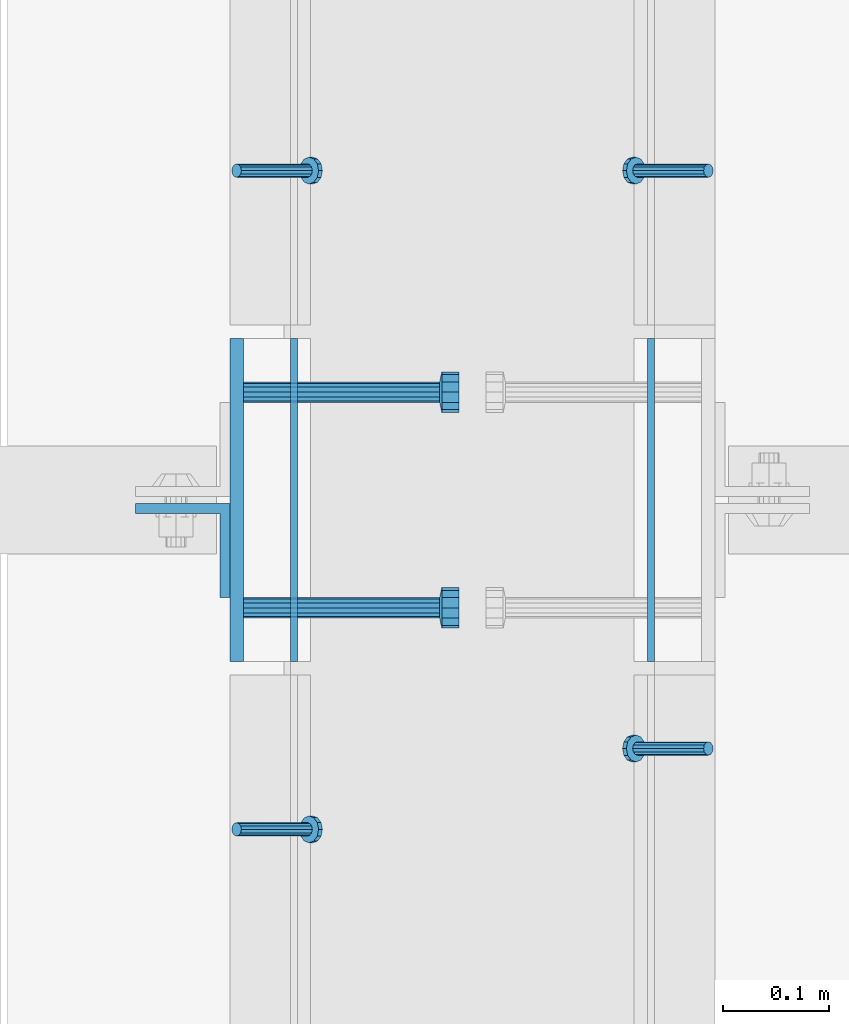
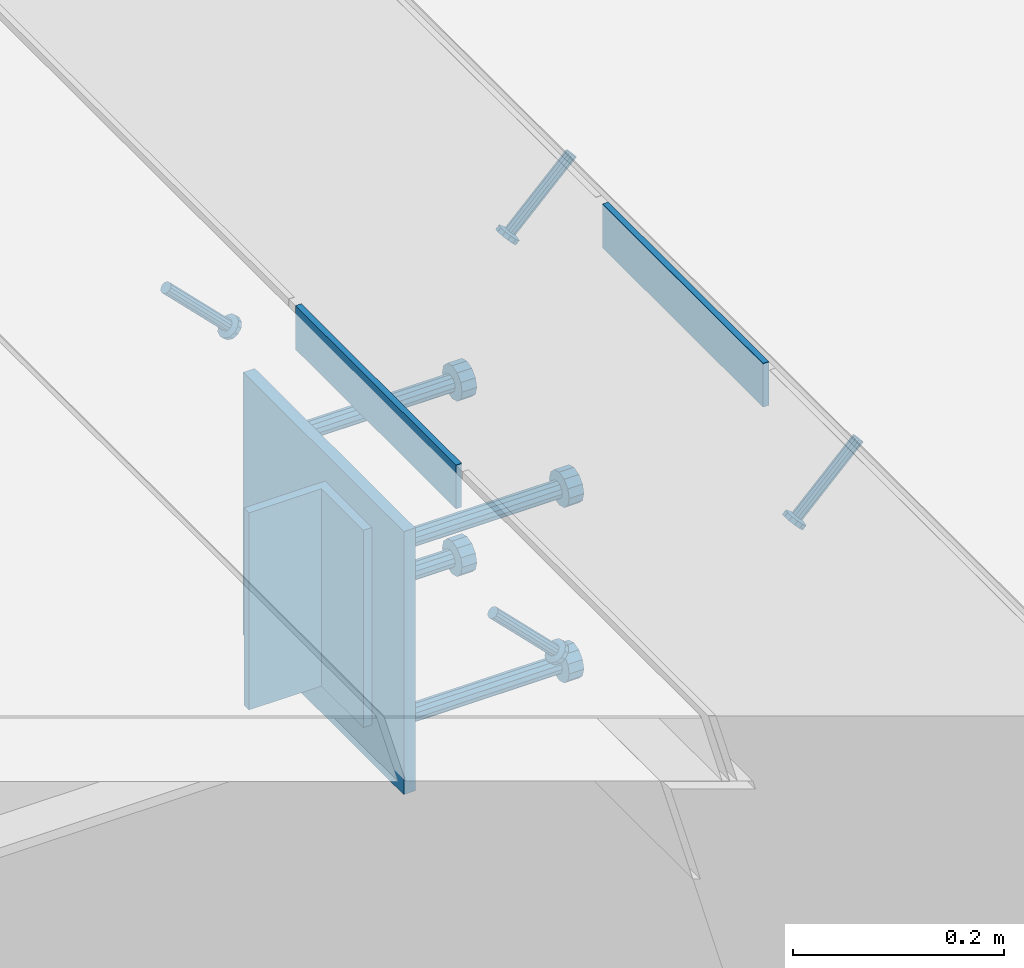
# One storey, part 2146 of 3843: 8 beams, 4 members, 7 elements without a shape of their own.
"""IFC2X3 building model written with IfcOpenShell, lengths in millimetres."""

from ifc_helpers import new_model, si_unit, frame, origin_with_axes, place, context, subcontext, project, spatial, faceted_brep, material, type_object, element, aggregate, save


model = new_model("IFC2X3")

# Units and contexts
model_context = context("Model", 3, precision=1e-05, world=origin_with_axes())
body_context = subcontext(model_context, "Body", "Model", "MODEL_VIEW")
ifc_project = project(units=[si_unit("LENGTHUNIT", "METRE", prefix="MILLI"), si_unit("AREAUNIT", "SQUARE_METRE"), si_unit("VOLUMEUNIT", "CUBIC_METRE"), si_unit("MASSUNIT", "GRAM", prefix="KILO"), si_unit("TIMEUNIT", "SECOND"), si_unit("PLANEANGLEUNIT", "RADIAN"), si_unit("SOLIDANGLEUNIT", "STERADIAN"), si_unit("THERMODYNAMICTEMPERATUREUNIT", "DEGREE_CELSIUS"), si_unit("LUMINOUSINTENSITYUNIT", "LUMEN")], contexts=[model_context])

# Site, building, storey
site_placement = place(None, origin_with_axes())
site = spatial("IfcSite", under=ifc_project, at=site_placement, CompositionType="ELEMENT")
building_placement = place(site_placement, origin_with_axes())
building = spatial("IfcBuilding", under=site, at=building_placement, Name="Undefined", CompositionType="ELEMENT")
storey_placement = place(building_placement, origin_with_axes())
storey = spatial("IfcBuildingStorey", under=building, at=storey_placement, Name="Undefined", CompositionType="ELEMENT", Elevation=0.0)

# Assembly, beam
assembly_1_placement = place(storey_placement, origin_with_axes())
assembly_1 = element("IfcElementAssembly", 1, at=assembly_1_placement, inside=storey, Name="EMBED PLATE", AssemblyPlace="NOTDEFINED", PredefinedType="RIGID_FRAME")
ifc_material_1 = material(Name="STEEL/A36")
beam_type_1 = type_object("IfcBeamType", PredefinedType="NOTDEFINED")
beam_1_placement = place(assembly_1_placement, frame((62391.9249969482, 16381.4125, 30454.6), z_axis=(0.0, 0.0, 1.0), x_axis=(0.0, -1.0, 0.0)))
beam_1 = element("IfcBeam", 2, at=beam_1_placement, type_object=beam_type_1, material=ifc_material_1, Name="PLATE", context=body_context, shape_type="Brep", body=[
    faceted_brep([(0.0, 3.17499999999927, -25.4000000000015), (0.0, 3.17499999999927, 25.4000000000015), (304.800000000003, 3.17500000000291, 25.4000000000015), (304.800000000003, 3.17500000000291, -25.4000000000015), (0.0, -3.17499999999927, 25.4000000000015), (304.800000000003, -3.17500000000291, 25.4000000000015), (0.0, -3.17499999999927, -25.4000000000015), (304.800000000003, -3.17500000000291, -25.4000000000015)], [[[0, 1, 2, 3]], [[1, 4, 5, 2]], [[4, 6, 7, 5]], [[6, 0, 3, 7]], [[5, 7, 3, 2]], [[6, 4, 1, 0]]]),
])

assembly_2_placement = place(storey_placement, origin_with_axes())
assembly_2 = element("IfcElementAssembly", 3, at=assembly_2_placement, inside=storey, Name="EMBED PLATE", AssemblyPlace="NOTDEFINED", PredefinedType="RIGID_FRAME")
beam_2_placement = place(assembly_2_placement, frame((62728.4750030518, 16076.6125, 30454.6), z_axis=(0.0, 0.0, 1.0), x_axis=(0.0, 1.0, 0.0)))
beam_2 = element("IfcBeam", 4, at=beam_2_placement, type_object=beam_type_1, material=ifc_material_1, Name="PLATE", context=body_context, shape_type="Brep", body=[
    faceted_brep([(0.0, 3.17499999999927, -25.4000000000015), (0.0, 3.17499999999927, 25.4000000000015), (304.800000000003, 3.17500000000291, 25.4000000000015), (304.800000000003, 3.17500000000291, -25.4000000000015), (0.0, -3.17499999999927, 25.4000000000015), (304.800000000003, -3.17500000000291, 25.4000000000015), (0.0, -3.17499999999927, -25.4000000000015), (304.800000000003, -3.17500000000291, -25.4000000000015)], [[[0, 1, 2, 3]], [[1, 4, 5, 2]], [[4, 6, 7, 5]], [[6, 0, 3, 7]], [[5, 7, 3, 2]], [[6, 4, 1, 0]]]),
])
aggregate(assembly_2, [beam_2])

# Assembly, member
assembly_3_placement = place(storey_placement, origin_with_axes())
assembly_3 = element("IfcElementAssembly", 5, at=assembly_3_placement, inside=storey, Name="ANGLE", AssemblyPlace="NOTDEFINED", PredefinedType="RIGID_FRAME")
ifc_material_2 = material(Name="STEEL/A108")
member_type = type_object("IfcMemberType", PredefinedType="NOTDEFINED")
member_1_placement = place(assembly_3_placement, frame((62782.449995556, 16539.3684967422, 30422.8500045777), z_axis=(0.0, -1.0, 0.0), x_axis=(-0.707106781186548, 0.0, -0.707106781186548)))
member_1 = element("IfcMember", 6, at=member_1_placement, type_object=member_type, material=ifc_material_2, Name="HEADED STUD ANCHOR", context=body_context, shape_type="Brep", body=[
    faceted_brep([(7.27595761418343e-12, -3.18000006675175, 5.5), (0.0, -5.49999999998363, 3.1800000667572), (94.4879985803855, -5.50000000011278, 3.1800000667572), (94.4879985803782, -3.18000006687362, 5.5), (0.0, -6.3499999046162, 0.0), (94.4879985803855, -6.34999990474535, 0.0), (0.0, -5.49999999998363, -3.1800000667572), (94.4879985803855, -5.50000000011278, -3.1800000667572), (7.27595761418343e-12, -3.18000006675175, -5.5), (94.4879985803782, -3.18000006687362, -5.5), (7.27595761418343e-12, -1.81898940354586e-12, -6.34999990463257), (94.4879985803782, -1.20053300634027e-10, -6.34999990463257), (0.0, 3.18000006675175, -5.5), (94.4879985803709, 3.18000006663351, -5.5), (7.27595761418343e-12, 5.49999999998363, -3.1800000667572), (94.4879985803709, 5.49999999987267, -3.1800000667572), (7.27595761418343e-12, 6.3499999046162, 0.0), (94.4879985803673, 6.34999990450706, 0.0), (7.27595761418343e-12, 5.49999999998363, 3.1800000667572), (94.4879985803709, 5.49999999987267, 3.1800000667572), (0.0, 3.18000006675175, 5.5), (94.4879985803709, 3.18000006663351, 5.5), (7.27595761418343e-12, -1.81898940354586e-12, 6.34999990463257), (94.4879985803782, -1.20053300634027e-10, 6.34999990463257), (96.5199985498621, -10.9899997712273, 6.34999990463257), (96.5199985498548, -6.34000015270249, 10.9899997711182), (96.5199985498621, -12.6999998093743, 0.0), (96.5199985498621, -10.9899997712273, -6.34999990463257), (96.5199985498548, -6.34000015270249, -10.9899997711182), (96.5199985498475, -1.21872290037572e-10, -12.6899995803833), (96.5199985498402, 6.34000015245874, -10.9899997711182), (96.519998549833, 10.9899997709817, -6.34999990463257), (96.519998549833, 12.6999998091305, 0.0), (96.519998549833, 10.9899997709817, 6.34999990463257), (96.5199985498402, 6.34000015245874, 10.9899997711182), (96.5199985498475, -1.21872290037572e-10, 12.6899995803833), (101.599998473539, -10.9899997712328, 6.34999990463257), (101.599998473532, -6.34000015270976, 10.9899997711182), (101.599998473539, -12.6999998093797, 0.0), (101.599998473539, -10.9899997712328, -6.34999990463257), (101.599998473532, -6.34000015270976, -10.9899997711182), (101.599998473524, -1.29148247651756e-10, -12.6899995803833), (101.599998473517, 6.34000015245329, -10.9899997711182), (101.59999847351, 10.9899997709763, -6.34999990463257), (101.599998473503, 12.6999998091196, 0.0), (101.59999847351, 10.9899997709763, 6.34999990463257), (101.599998473517, 6.34000015245329, 10.9899997711182), (101.599998473524, -1.29148247651756e-10, 12.6899995803833)], [[[0, 1, 2, 3]], [[1, 4, 5, 2]], [[4, 6, 7, 5]], [[6, 8, 9, 7]], [[8, 10, 11, 9]], [[10, 12, 13, 11]], [[12, 14, 15, 13]], [[14, 16, 17, 15]], [[16, 18, 19, 17]], [[18, 20, 21, 19]], [[20, 22, 23, 21]], [[22, 0, 3, 23]], [[22, 20, 18, 16, 14, 12, 10, 8, 6, 4, 1, 0]], [[3, 2, 24, 25]], [[2, 5, 26, 24]], [[5, 7, 27, 26]], [[7, 9, 28, 27]], [[9, 11, 29, 28]], [[11, 13, 30, 29]], [[13, 15, 31, 30]], [[15, 17, 32, 31]], [[17, 19, 33, 32]], [[19, 21, 34, 33]], [[21, 23, 35, 34]], [[23, 3, 25, 35]], [[25, 24, 36, 37]], [[24, 26, 38, 36]], [[26, 27, 39, 38]], [[27, 28, 40, 39]], [[28, 29, 41, 40]], [[29, 30, 42, 41]], [[30, 31, 43, 42]], [[31, 32, 44, 43]], [[32, 33, 45, 44]], [[33, 34, 46, 45]], [[34, 35, 47, 46]], [[35, 25, 37, 47]], [[38, 39, 40, 41, 42, 43, 44, 45, 46, 47, 37, 36]]]),
])
aggregate(assembly_3, [member_1])

assembly_4_placement = place(storey_placement, origin_with_axes())
assembly_4 = element("IfcElementAssembly", 7, at=assembly_4_placement, inside=storey, Name="ANGLE", AssemblyPlace="NOTDEFINED", PredefinedType="RIGID_FRAME")
member_2_placement = place(assembly_4_placement, frame((62782.4499889116, 15994.8560164511, 30422.8500045777), z_axis=(0.0, -1.0, 0.0), x_axis=(-0.707106781186548, 0.0, -0.707106781186548)))
member_2 = element("IfcMember", 8, at=member_2_placement, type_object=member_type, material=ifc_material_2, Name="HEADED STUD ANCHOR", context=body_context, shape_type="Brep", body=[
    faceted_brep([(7.27595761418343e-12, -3.18000006675175, 5.5), (0.0, -5.49999999998363, 3.1800000667572), (94.4879985803855, -5.50000000011278, 3.1800000667572), (94.4879985803782, -3.18000006687362, 5.5), (0.0, -6.3499999046162, 0.0), (94.4879985803855, -6.34999990474535, 0.0), (0.0, -5.49999999998363, -3.1800000667572), (94.4879985803855, -5.50000000011278, -3.1800000667572), (7.27595761418343e-12, -3.18000006675175, -5.5), (94.4879985803782, -3.18000006687362, -5.5), (7.27595761418343e-12, -1.81898940354586e-12, -6.34999990463257), (94.4879985803782, -1.20053300634027e-10, -6.34999990463257), (0.0, 3.18000006675175, -5.5), (94.4879985803709, 3.18000006663351, -5.5), (7.27595761418343e-12, 5.49999999998363, -3.1800000667572), (94.4879985803709, 5.49999999987267, -3.1800000667572), (7.27595761418343e-12, 6.3499999046162, 0.0), (94.4879985803673, 6.34999990450706, 0.0), (7.27595761418343e-12, 5.49999999998363, 3.1800000667572), (94.4879985803709, 5.49999999987267, 3.1800000667572), (0.0, 3.18000006675175, 5.5), (94.4879985803709, 3.18000006663351, 5.5), (7.27595761418343e-12, -1.81898940354586e-12, 6.34999990463257), (94.4879985803782, -1.20053300634027e-10, 6.34999990463257), (96.5199985498621, -10.9899997712273, 6.34999990463257), (96.5199985498548, -6.34000015270249, 10.9899997711182), (96.5199985498621, -12.6999998093743, 0.0), (96.5199985498621, -10.9899997712273, -6.34999990463257), (96.5199985498548, -6.34000015270249, -10.9899997711182), (96.5199985498475, -1.21872290037572e-10, -12.6899995803833), (96.5199985498402, 6.34000015245874, -10.9899997711182), (96.519998549833, 10.9899997709817, -6.34999990463257), (96.519998549833, 12.6999998091305, 0.0), (96.519998549833, 10.9899997709817, 6.34999990463257), (96.5199985498402, 6.34000015245874, 10.9899997711182), (96.5199985498475, -1.21872290037572e-10, 12.6899995803833), (101.599998473539, -10.9899997712328, 6.34999990463257), (101.599998473532, -6.34000015270976, 10.9899997711182), (101.599998473539, -12.6999998093797, 0.0), (101.599998473539, -10.9899997712328, -6.34999990463257), (101.599998473532, -6.34000015270976, -10.9899997711182), (101.599998473524, -1.29148247651756e-10, -12.6899995803833), (101.599998473517, 6.34000015245329, -10.9899997711182), (101.59999847351, 10.9899997709763, -6.34999990463257), (101.599998473503, 12.6999998091196, 0.0), (101.59999847351, 10.9899997709763, 6.34999990463257), (101.599998473517, 6.34000015245329, 10.9899997711182), (101.599998473524, -1.29148247651756e-10, 12.6899995803833)], [[[0, 1, 2, 3]], [[1, 4, 5, 2]], [[4, 6, 7, 5]], [[6, 8, 9, 7]], [[8, 10, 11, 9]], [[10, 12, 13, 11]], [[12, 14, 15, 13]], [[14, 16, 17, 15]], [[16, 18, 19, 17]], [[18, 20, 21, 19]], [[20, 22, 23, 21]], [[22, 0, 3, 23]], [[22, 20, 18, 16, 14, 12, 10, 8, 6, 4, 1, 0]], [[3, 2, 24, 25]], [[2, 5, 26, 24]], [[5, 7, 27, 26]], [[7, 9, 28, 27]], [[9, 11, 29, 28]], [[11, 13, 30, 29]], [[13, 15, 31, 30]], [[15, 17, 32, 31]], [[17, 19, 33, 32]], [[19, 21, 34, 33]], [[21, 23, 35, 34]], [[23, 3, 25, 35]], [[25, 24, 36, 37]], [[24, 26, 38, 36]], [[26, 27, 39, 38]], [[27, 28, 40, 39]], [[28, 29, 41, 40]], [[29, 30, 42, 41]], [[30, 31, 43, 42]], [[31, 32, 44, 43]], [[32, 33, 45, 44]], [[33, 34, 46, 45]], [[34, 35, 47, 46]], [[35, 25, 37, 47]], [[38, 39, 40, 41, 42, 43, 44, 45, 46, 47, 37, 36]]]),
])
aggregate(assembly_4, [member_2])

assembly_5_placement = place(storey_placement, origin_with_axes())
assembly_5 = element("IfcElementAssembly", 9, at=assembly_5_placement, inside=storey, Name="ANGLE", AssemblyPlace="NOTDEFINED", PredefinedType="RIGID_FRAME")
member_3_placement = place(assembly_5_placement, frame((62337.9500063455, 16539.368527729, 30422.8500045777), z_axis=(0.0, 1.0, 0.0), x_axis=(0.707106781186548, 0.0, -0.707106781186548)))
member_3 = element("IfcMember", 10, at=member_3_placement, type_object=member_type, material=ifc_material_2, Name="HEADED STUD ANCHOR", context=body_context, shape_type="Brep", body=[
    faceted_brep([(7.27595761418343e-12, -3.18000006675175, 5.5), (0.0, -5.49999999998363, 3.1800000667572), (94.4879985803855, -5.50000000011278, 3.1800000667572), (94.4879985803782, -3.18000006687362, 5.5), (0.0, -6.3499999046162, 0.0), (94.4879985803855, -6.34999990474535, 0.0), (0.0, -5.49999999998363, -3.1800000667572), (94.4879985803855, -5.50000000011278, -3.1800000667572), (7.27595761418343e-12, -3.18000006675175, -5.5), (94.4879985803782, -3.18000006687362, -5.5), (7.27595761418343e-12, -1.81898940354586e-12, -6.34999990463257), (94.4879985803782, -1.20053300634027e-10, -6.34999990463257), (0.0, 3.18000006675175, -5.5), (94.4879985803709, 3.18000006663351, -5.5), (7.27595761418343e-12, 5.49999999998363, -3.1800000667572), (94.4879985803709, 5.49999999987267, -3.1800000667572), (7.27595761418343e-12, 6.3499999046162, 0.0), (94.4879985803673, 6.34999990450706, 0.0), (7.27595761418343e-12, 5.49999999998363, 3.1800000667572), (94.4879985803709, 5.49999999987267, 3.1800000667572), (0.0, 3.18000006675175, 5.5), (94.4879985803709, 3.18000006663351, 5.5), (7.27595761418343e-12, -1.81898940354586e-12, 6.34999990463257), (94.4879985803782, -1.20053300634027e-10, 6.34999990463257), (96.5199985498621, -10.9899997712273, 6.34999990463257), (96.5199985498548, -6.34000015270249, 10.9899997711182), (96.5199985498621, -12.6999998093743, 0.0), (96.5199985498621, -10.9899997712273, -6.34999990463257), (96.5199985498548, -6.34000015270249, -10.9899997711182), (96.5199985498475, -1.21872290037572e-10, -12.6899995803833), (96.5199985498402, 6.34000015245874, -10.9899997711182), (96.519998549833, 10.9899997709817, -6.34999990463257), (96.519998549833, 12.6999998091305, 0.0), (96.519998549833, 10.9899997709817, 6.34999990463257), (96.5199985498402, 6.34000015245874, 10.9899997711182), (96.5199985498475, -1.21872290037572e-10, 12.6899995803833), (101.599998473539, -10.9899997712328, 6.34999990463257), (101.599998473532, -6.34000015270976, 10.9899997711182), (101.599998473539, -12.6999998093797, 0.0), (101.599998473539, -10.9899997712328, -6.34999990463257), (101.599998473532, -6.34000015270976, -10.9899997711182), (101.599998473524, -1.29148247651756e-10, -12.6899995803833), (101.599998473517, 6.34000015245329, -10.9899997711182), (101.59999847351, 10.9899997709763, -6.34999990463257), (101.599998473503, 12.6999998091196, 0.0), (101.59999847351, 10.9899997709763, 6.34999990463257), (101.599998473517, 6.34000015245329, 10.9899997711182), (101.599998473524, -1.29148247651756e-10, 12.6899995803833)], [[[0, 1, 2, 3]], [[1, 4, 5, 2]], [[4, 6, 7, 5]], [[6, 8, 9, 7]], [[8, 10, 11, 9]], [[10, 12, 13, 11]], [[12, 14, 15, 13]], [[14, 16, 17, 15]], [[16, 18, 19, 17]], [[18, 20, 21, 19]], [[20, 22, 23, 21]], [[22, 0, 3, 23]], [[22, 20, 18, 16, 14, 12, 10, 8, 6, 4, 1, 0]], [[3, 2, 24, 25]], [[2, 5, 26, 24]], [[5, 7, 27, 26]], [[7, 9, 28, 27]], [[9, 11, 29, 28]], [[11, 13, 30, 29]], [[13, 15, 31, 30]], [[15, 17, 32, 31]], [[17, 19, 33, 32]], [[19, 21, 34, 33]], [[21, 23, 35, 34]], [[23, 3, 25, 35]], [[25, 24, 36, 37]], [[24, 26, 38, 36]], [[26, 27, 39, 38]], [[27, 28, 40, 39]], [[28, 29, 41, 40]], [[29, 30, 42, 41]], [[30, 31, 43, 42]], [[31, 32, 44, 43]], [[32, 33, 45, 44]], [[33, 34, 46, 45]], [[34, 35, 47, 46]], [[35, 25, 37, 47]], [[38, 39, 40, 41, 42, 43, 44, 45, 46, 47, 37, 36]]]),
])
aggregate(assembly_5, [member_3])

assembly_6_placement = place(storey_placement, origin_with_axes())
assembly_6 = element("IfcElementAssembly", 11, at=assembly_6_placement, inside=storey, Name="ANGLE", AssemblyPlace="NOTDEFINED", PredefinedType="RIGID_FRAME")
member_4_placement = place(assembly_6_placement, frame((62337.9500063455, 15918.656027729, 30422.8500045777), z_axis=(0.0, 1.0, 0.0), x_axis=(0.707106781186548, 0.0, -0.707106781186548)))
member_4 = element("IfcMember", 12, at=member_4_placement, type_object=member_type, material=ifc_material_2, Name="HEADED STUD ANCHOR", context=body_context, shape_type="Brep", body=[
    faceted_brep([(7.27595761418343e-12, -3.18000006675175, 5.5), (0.0, -5.49999999998363, 3.1800000667572), (94.4879985803855, -5.50000000011278, 3.1800000667572), (94.4879985803782, -3.18000006687362, 5.5), (0.0, -6.3499999046162, 0.0), (94.4879985803855, -6.34999990474535, 0.0), (0.0, -5.49999999998363, -3.1800000667572), (94.4879985803855, -5.50000000011278, -3.1800000667572), (7.27595761418343e-12, -3.18000006675175, -5.5), (94.4879985803782, -3.18000006687362, -5.5), (7.27595761418343e-12, -1.81898940354586e-12, -6.34999990463257), (94.4879985803782, -1.20053300634027e-10, -6.34999990463257), (0.0, 3.18000006675175, -5.5), (94.4879985803709, 3.18000006663351, -5.5), (7.27595761418343e-12, 5.49999999998363, -3.1800000667572), (94.4879985803709, 5.49999999987267, -3.1800000667572), (7.27595761418343e-12, 6.3499999046162, 0.0), (94.4879985803673, 6.34999990450706, 0.0), (7.27595761418343e-12, 5.49999999998363, 3.1800000667572), (94.4879985803709, 5.49999999987267, 3.1800000667572), (0.0, 3.18000006675175, 5.5), (94.4879985803709, 3.18000006663351, 5.5), (7.27595761418343e-12, -1.81898940354586e-12, 6.34999990463257), (94.4879985803782, -1.20053300634027e-10, 6.34999990463257), (96.5199985498621, -10.9899997712273, 6.34999990463257), (96.5199985498548, -6.34000015270249, 10.9899997711182), (96.5199985498621, -12.6999998093743, 0.0), (96.5199985498621, -10.9899997712273, -6.34999990463257), (96.5199985498548, -6.34000015270249, -10.9899997711182), (96.5199985498475, -1.21872290037572e-10, -12.6899995803833), (96.5199985498402, 6.34000015245874, -10.9899997711182), (96.519998549833, 10.9899997709817, -6.34999990463257), (96.519998549833, 12.6999998091305, 0.0), (96.519998549833, 10.9899997709817, 6.34999990463257), (96.5199985498402, 6.34000015245874, 10.9899997711182), (96.5199985498475, -1.21872290037572e-10, 12.6899995803833), (101.599998473539, -10.9899997712328, 6.34999990463257), (101.599998473532, -6.34000015270976, 10.9899997711182), (101.599998473539, -12.6999998093797, 0.0), (101.599998473539, -10.9899997712328, -6.34999990463257), (101.599998473532, -6.34000015270976, -10.9899997711182), (101.599998473524, -1.29148247651756e-10, -12.6899995803833), (101.599998473517, 6.34000015245329, -10.9899997711182), (101.59999847351, 10.9899997709763, -6.34999990463257), (101.599998473503, 12.6999998091196, 0.0), (101.59999847351, 10.9899997709763, 6.34999990463257), (101.599998473517, 6.34000015245329, 10.9899997711182), (101.599998473524, -1.29148247651756e-10, 12.6899995803833)], [[[0, 1, 2, 3]], [[1, 4, 5, 2]], [[4, 6, 7, 5]], [[6, 8, 9, 7]], [[8, 10, 11, 9]], [[10, 12, 13, 11]], [[12, 14, 15, 13]], [[14, 16, 17, 15]], [[16, 18, 19, 17]], [[18, 20, 21, 19]], [[20, 22, 23, 21]], [[22, 0, 3, 23]], [[22, 20, 18, 16, 14, 12, 10, 8, 6, 4, 1, 0]], [[3, 2, 24, 25]], [[2, 5, 26, 24]], [[5, 7, 27, 26]], [[7, 9, 28, 27]], [[9, 11, 29, 28]], [[11, 13, 30, 29]], [[13, 15, 31, 30]], [[15, 17, 32, 31]], [[17, 19, 33, 32]], [[19, 21, 34, 33]], [[21, 23, 35, 34]], [[23, 3, 25, 35]], [[25, 24, 36, 37]], [[24, 26, 38, 36]], [[26, 27, 39, 38]], [[27, 28, 40, 39]], [[28, 29, 41, 40]], [[29, 30, 42, 41]], [[30, 31, 43, 42]], [[31, 32, 44, 43]], [[32, 33, 45, 44]], [[33, 34, 46, 45]], [[34, 35, 47, 46]], [[35, 25, 37, 47]], [[38, 39, 40, 41, 42, 43, 44, 45, 46, 47, 37, 36]]]),
])
aggregate(assembly_6, [member_4])

# Beam
beam_type_2 = type_object("IfcBeamType", PredefinedType="NOTDEFINED")
beam_3_placement = place(assembly_1_placement, frame((62337.9499969482, 16229.0125, 30422.85), z_axis=(0.0, -1.0, 0.0), x_axis=(0.0, 0.0, -1.0)))
beam_3 = element("IfcBeam", 13, at=beam_3_placement, type_object=beam_type_2, material=ifc_material_1, Name="EMBED PLATE", context=body_context, shape_type="Brep", body=[
    faceted_brep([(-1.0550138540566e-10, 6.34999999999854, -152.400000000664), (1.0550138540566e-10, 6.34999999999854, 152.400000000656), (304.799999999999, 6.34999999999854, 152.400000000001), (304.799999999999, 6.34999999999854, -152.400000000001), (1.0550138540566e-10, -6.34999999999854, 152.400000000656), (304.799999999999, -6.34999999999854, 152.400000000001), (-1.0550138540566e-10, -6.34999999999854, -152.400000000664), (304.799999999999, -6.34999999999854, -152.400000000001)], [[[0, 1, 2, 3]], [[1, 4, 5, 2]], [[4, 6, 7, 5]], [[6, 0, 3, 7]], [[5, 7, 3, 2]], [[6, 4, 1, 0]]]),
])

# Assembly, beam
assembly_7_placement = place(storey_placement, origin_with_axes())
assembly_7 = element("IfcElementAssembly", 14, at=assembly_7_placement, inside=storey, Name="BEAM", AssemblyPlace="NOTDEFINED", PredefinedType="RIGID_FRAME")
beam_type_3 = type_object("IfcBeamType", Name="L3-1/2X3-1/2X3/8", PredefinedType="NOTDEFINED")
beam_4_placement = place(assembly_7_placement, frame((62287.1499969482, 16181.3875, 30391.1), z_axis=(0.0, -1.0, 0.0), x_axis=(0.0, 0.0, -1.0)))
beam_4 = element("IfcBeam", 15, at=beam_4_placement, type_object=beam_type_3, material=ifc_material_1, Name="ANGLE", ObjectType="L3-1/2X3-1/2X3/8", context=body_context, shape_type="Brep", body=[
    faceted_brep([(-3.63797880709171e-12, 44.4499999999971, -44.4500000000007), (-3.63797880709171e-12, 44.4499999999971, 44.4500000000007), (228.600000000006, 44.4499999999971, 44.4500000000007), (228.600000000006, 44.4499999999971, -44.4500000000007), (0.0, 34.9250000000029, 44.4500000000007), (228.600000000006, 34.9250000000029, 44.4500000000007), (0.0, 34.9250000000029, -34.9250000000029), (228.600000000006, 34.9250000000029, -34.9249999999993), (0.0, -44.4499999999971, -34.9249999999993), (228.600000000006, -44.4499999999971, -34.9249999999993), (3.63797880709171e-12, -44.4499999999971, -44.4500000000007), (228.600000000006, -44.4499999999971, -44.4500000000007)], [[[0, 1, 2, 3]], [[1, 4, 5, 2]], [[4, 6, 7, 5]], [[6, 8, 9, 7]], [[8, 10, 11, 9]], [[10, 0, 3, 11]], [[5, 7, 9, 11, 3, 2]], [[10, 8, 6, 4, 1, 0]]]),
])
aggregate(assembly_7, [beam_4])

# Beam
beam_type_4 = type_object("IfcBeamType", PredefinedType="NOTDEFINED")
beam_5_placement = place(assembly_1_placement, frame((62344.2999969482, 16330.6125, 30372.05), z_axis=(0.0, 1.0, 0.0), x_axis=(1.0, 0.0, 0.0)))
beam_5 = element("IfcBeam", 16, at=beam_5_placement, type_object=beam_type_4, material=ifc_material_2, Name="HEADED STUD ANCHOR", context=body_context, shape_type="Brep", body=[
    faceted_brep([(0.0, -9.52000045776367, 0.0), (0.0, -8.25, -4.76000022888184), (184.912000000004, -8.25, -4.76000022888184), (184.912000000004, -9.52000045776367, 0.0), (0.0, -4.76000022888184, -8.25), (184.912000000004, -4.76000022888184, -8.25), (0.0, 0.0, -9.52000045776367), (184.912000000004, 0.0, -9.52000045776367), (0.0, 4.76000022888184, -8.25), (184.912000000004, 4.76000022888184, -8.25), (0.0, 8.25, -4.76000022888184), (184.912000000004, 8.25, -4.76000022888184), (0.0, 9.52000045776367, 0.0), (184.912000000004, 9.52000045776367, 0.0), (0.0, 8.25, 4.76000022888184), (184.912000000004, 8.25, 4.76000022888184), (0.0, 4.76000022888184, 8.25), (184.912000000004, 4.76000022888184, 8.25), (0.0, 0.0, 9.52000045776367), (184.912000000004, 0.0, 9.52000045776367), (0.0, -4.76000022888184, 8.25), (184.912000000004, -4.76000022888184, 8.25), (0.0, -8.25, 4.76000022888184), (184.912000000004, -8.25, 4.76000022888184), (186.944000000003, -16.5, -9.52000045776367), (186.944000000003, -19.0499992370605, 0.0), (186.944000000003, -9.52000045776367, -16.5), (186.944000000003, 0.0, -19.0499992370605), (186.944000000003, 9.52000045776367, -16.5), (186.944000000003, 16.5, -9.52000045776367), (186.944000000003, 19.0499992370605, 0.0), (186.944000000003, 16.5, 9.52000045776367), (186.944000000003, 9.52000045776367, 16.5), (186.944000000003, 0.0, 19.0499992370605), (186.944000000003, -9.52000045776367, 16.5), (186.944000000003, -16.5, 9.52000045776367), (203.199999999997, -16.5, -9.52000045776367), (203.199999999997, -19.0499992370605, 0.0), (203.199999999997, -9.52000045776367, -16.5), (203.199999999997, 0.0, -19.0499992370605), (203.199999999997, 9.52000045776367, -16.5), (203.199999999997, 16.5, -9.52000045776367), (203.199999999997, 19.0499992370605, 0.0), (203.199999999997, 16.5, 9.52000045776367), (203.199999999997, 9.52000045776367, 16.5), (203.199999999997, 0.0, 19.0499992370605), (203.199999999997, -9.52000045776367, 16.5), (203.199999999997, -16.5, 9.52000045776367)], [[[0, 1, 2, 3]], [[1, 4, 5, 2]], [[4, 6, 7, 5]], [[6, 8, 9, 7]], [[8, 10, 11, 9]], [[10, 12, 13, 11]], [[12, 14, 15, 13]], [[14, 16, 17, 15]], [[16, 18, 19, 17]], [[18, 20, 21, 19]], [[20, 22, 23, 21]], [[22, 0, 3, 23]], [[22, 20, 18, 16, 14, 12, 10, 8, 6, 4, 1, 0]], [[3, 2, 24, 25]], [[2, 5, 26, 24]], [[5, 7, 27, 26]], [[7, 9, 28, 27]], [[9, 11, 29, 28]], [[11, 13, 30, 29]], [[13, 15, 31, 30]], [[15, 17, 32, 31]], [[17, 19, 33, 32]], [[19, 21, 34, 33]], [[21, 23, 35, 34]], [[23, 3, 25, 35]], [[25, 24, 36, 37]], [[24, 26, 38, 36]], [[26, 27, 39, 38]], [[27, 28, 40, 39]], [[28, 29, 41, 40]], [[29, 30, 42, 41]], [[30, 31, 43, 42]], [[31, 32, 44, 43]], [[32, 33, 45, 44]], [[33, 34, 46, 45]], [[34, 35, 47, 46]], [[35, 25, 37, 47]], [[38, 39, 40, 41, 42, 43, 44, 45, 46, 47, 37, 36]]]),
])

beam_6_placement = place(assembly_1_placement, frame((62344.2999969482, 16330.6125, 30168.85), z_axis=(0.0, 1.0, 0.0), x_axis=(1.0, 0.0, 0.0)))
beam_6 = element("IfcBeam", 17, at=beam_6_placement, type_object=beam_type_4, material=ifc_material_2, Name="HEADED STUD ANCHOR", context=body_context, shape_type="Brep", body=[
    faceted_brep([(0.0, -9.52000045776367, 0.0), (0.0, -8.25, -4.76000022888184), (184.912000000004, -8.25, -4.76000022888184), (184.912000000004, -9.52000045776367, 0.0), (0.0, -4.76000022888184, -8.25), (184.912000000004, -4.76000022888184, -8.25), (0.0, 0.0, -9.52000045776367), (184.912000000004, 0.0, -9.52000045776367), (0.0, 4.76000022888184, -8.25), (184.912000000004, 4.76000022888184, -8.25), (0.0, 8.25, -4.76000022888184), (184.912000000004, 8.25, -4.76000022888184), (0.0, 9.52000045776367, 0.0), (184.912000000004, 9.52000045776367, 0.0), (0.0, 8.25, 4.76000022888184), (184.912000000004, 8.25, 4.76000022888184), (0.0, 4.76000022888184, 8.25), (184.912000000004, 4.76000022888184, 8.25), (0.0, 0.0, 9.52000045776367), (184.912000000004, 0.0, 9.52000045776367), (0.0, -4.76000022888184, 8.25), (184.912000000004, -4.76000022888184, 8.25), (0.0, -8.25, 4.76000022888184), (184.912000000004, -8.25, 4.76000022888184), (186.944000000003, -16.5, -9.52000045776367), (186.944000000003, -19.0499992370605, 0.0), (186.944000000003, -9.52000045776367, -16.5), (186.944000000003, 0.0, -19.0499992370605), (186.944000000003, 9.52000045776367, -16.5), (186.944000000003, 16.5, -9.52000045776367), (186.944000000003, 19.0499992370605, 0.0), (186.944000000003, 16.5, 9.52000045776367), (186.944000000003, 9.52000045776367, 16.5), (186.944000000003, 0.0, 19.0499992370605), (186.944000000003, -9.52000045776367, 16.5), (186.944000000003, -16.5, 9.52000045776367), (203.199999999997, -16.5, -9.52000045776367), (203.199999999997, -19.0499992370605, 0.0), (203.199999999997, -9.52000045776367, -16.5), (203.199999999997, 0.0, -19.0499992370605), (203.199999999997, 9.52000045776367, -16.5), (203.199999999997, 16.5, -9.52000045776367), (203.199999999997, 19.0499992370605, 0.0), (203.199999999997, 16.5, 9.52000045776367), (203.199999999997, 9.52000045776367, 16.5), (203.199999999997, 0.0, 19.0499992370605), (203.199999999997, -9.52000045776367, 16.5), (203.199999999997, -16.5, 9.52000045776367)], [[[0, 1, 2, 3]], [[1, 4, 5, 2]], [[4, 6, 7, 5]], [[6, 8, 9, 7]], [[8, 10, 11, 9]], [[10, 12, 13, 11]], [[12, 14, 15, 13]], [[14, 16, 17, 15]], [[16, 18, 19, 17]], [[18, 20, 21, 19]], [[20, 22, 23, 21]], [[22, 0, 3, 23]], [[22, 20, 18, 16, 14, 12, 10, 8, 6, 4, 1, 0]], [[3, 2, 24, 25]], [[2, 5, 26, 24]], [[5, 7, 27, 26]], [[7, 9, 28, 27]], [[9, 11, 29, 28]], [[11, 13, 30, 29]], [[13, 15, 31, 30]], [[15, 17, 32, 31]], [[17, 19, 33, 32]], [[19, 21, 34, 33]], [[21, 23, 35, 34]], [[23, 3, 25, 35]], [[25, 24, 36, 37]], [[24, 26, 38, 36]], [[26, 27, 39, 38]], [[27, 28, 40, 39]], [[28, 29, 41, 40]], [[29, 30, 42, 41]], [[30, 31, 43, 42]], [[31, 32, 44, 43]], [[32, 33, 45, 44]], [[33, 34, 46, 45]], [[34, 35, 47, 46]], [[35, 25, 37, 47]], [[38, 39, 40, 41, 42, 43, 44, 45, 46, 47, 37, 36]]]),
])

beam_7_placement = place(assembly_1_placement, frame((62344.2999969482, 16127.4125, 30372.05), z_axis=(0.0, 1.0, 0.0), x_axis=(1.0, 0.0, 0.0)))
beam_7 = element("IfcBeam", 18, at=beam_7_placement, type_object=beam_type_4, material=ifc_material_1, Name="PLATE", context=body_context, shape_type="Brep", body=[
    faceted_brep([(0.0, -9.52000045776367, 0.0), (0.0, -8.25, -4.76000022888184), (184.912000000004, -8.25, -4.76000022888184), (184.912000000004, -9.52000045776367, 0.0), (0.0, -4.76000022888184, -8.25), (184.912000000004, -4.76000022888184, -8.25), (0.0, 0.0, -9.52000045776367), (184.912000000004, 0.0, -9.52000045776367), (0.0, 4.76000022888184, -8.25), (184.912000000004, 4.76000022888184, -8.25), (0.0, 8.25, -4.76000022888184), (184.912000000004, 8.25, -4.76000022888184), (0.0, 9.52000045776367, 0.0), (184.912000000004, 9.52000045776367, 0.0), (0.0, 8.25, 4.76000022888184), (184.912000000004, 8.25, 4.76000022888184), (0.0, 4.76000022888184, 8.25), (184.912000000004, 4.76000022888184, 8.25), (0.0, 0.0, 9.52000045776367), (184.912000000004, 0.0, 9.52000045776367), (0.0, -4.76000022888184, 8.25), (184.912000000004, -4.76000022888184, 8.25), (0.0, -8.25, 4.76000022888184), (184.912000000004, -8.25, 4.76000022888184), (186.944000000003, -16.5, -9.52000045776367), (186.944000000003, -19.0499992370605, 0.0), (186.944000000003, -9.52000045776367, -16.5), (186.944000000003, 0.0, -19.0499992370605), (186.944000000003, 9.52000045776367, -16.5), (186.944000000003, 16.5, -9.52000045776367), (186.944000000003, 19.0499992370605, 0.0), (186.944000000003, 16.5, 9.52000045776367), (186.944000000003, 9.52000045776367, 16.5), (186.944000000003, 0.0, 19.0499992370605), (186.944000000003, -9.52000045776367, 16.5), (186.944000000003, -16.5, 9.52000045776367), (203.199999999997, -16.5, -9.52000045776367), (203.199999999997, -19.0499992370605, 0.0), (203.199999999997, -9.52000045776367, -16.5), (203.199999999997, 0.0, -19.0499992370605), (203.199999999997, 9.52000045776367, -16.5), (203.199999999997, 16.5, -9.52000045776367), (203.199999999997, 19.0499992370605, 0.0), (203.199999999997, 16.5, 9.52000045776367), (203.199999999997, 9.52000045776367, 16.5), (203.199999999997, 0.0, 19.0499992370605), (203.199999999997, -9.52000045776367, 16.5), (203.199999999997, -16.5, 9.52000045776367)], [[[0, 1, 2, 3]], [[1, 4, 5, 2]], [[4, 6, 7, 5]], [[6, 8, 9, 7]], [[8, 10, 11, 9]], [[10, 12, 13, 11]], [[12, 14, 15, 13]], [[14, 16, 17, 15]], [[16, 18, 19, 17]], [[18, 20, 21, 19]], [[20, 22, 23, 21]], [[22, 0, 3, 23]], [[22, 20, 18, 16, 14, 12, 10, 8, 6, 4, 1, 0]], [[3, 2, 24, 25]], [[2, 5, 26, 24]], [[5, 7, 27, 26]], [[7, 9, 28, 27]], [[9, 11, 29, 28]], [[11, 13, 30, 29]], [[13, 15, 31, 30]], [[15, 17, 32, 31]], [[17, 19, 33, 32]], [[19, 21, 34, 33]], [[21, 23, 35, 34]], [[23, 3, 25, 35]], [[25, 24, 36, 37]], [[24, 26, 38, 36]], [[26, 27, 39, 38]], [[27, 28, 40, 39]], [[28, 29, 41, 40]], [[29, 30, 42, 41]], [[30, 31, 43, 42]], [[31, 32, 44, 43]], [[32, 33, 45, 44]], [[33, 34, 46, 45]], [[34, 35, 47, 46]], [[35, 25, 37, 47]], [[38, 39, 40, 41, 42, 43, 44, 45, 46, 47, 37, 36]]]),
])

beam_8_placement = place(assembly_1_placement, frame((62344.2999969482, 16127.4125, 30168.85), z_axis=(0.0, 1.0, 0.0), x_axis=(1.0, 0.0, 0.0)))
beam_8 = element("IfcBeam", 19, at=beam_8_placement, type_object=beam_type_4, material=ifc_material_2, Name="HEADED STUD ANCHOR", context=body_context, shape_type="Brep", body=[
    faceted_brep([(0.0, -9.52000045776367, 0.0), (0.0, -8.25, -4.76000022888184), (184.912000000004, -8.25, -4.76000022888184), (184.912000000004, -9.52000045776367, 0.0), (0.0, -4.76000022888184, -8.25), (184.912000000004, -4.76000022888184, -8.25), (0.0, 0.0, -9.52000045776367), (184.912000000004, 0.0, -9.52000045776367), (0.0, 4.76000022888184, -8.25), (184.912000000004, 4.76000022888184, -8.25), (0.0, 8.25, -4.76000022888184), (184.912000000004, 8.25, -4.76000022888184), (0.0, 9.52000045776367, 0.0), (184.912000000004, 9.52000045776367, 0.0), (0.0, 8.25, 4.76000022888184), (184.912000000004, 8.25, 4.76000022888184), (0.0, 4.76000022888184, 8.25), (184.912000000004, 4.76000022888184, 8.25), (0.0, 0.0, 9.52000045776367), (184.912000000004, 0.0, 9.52000045776367), (0.0, -4.76000022888184, 8.25), (184.912000000004, -4.76000022888184, 8.25), (0.0, -8.25, 4.76000022888184), (184.912000000004, -8.25, 4.76000022888184), (186.944000000003, -16.5, -9.52000045776367), (186.944000000003, -19.0499992370605, 0.0), (186.944000000003, -9.52000045776367, -16.5), (186.944000000003, 0.0, -19.0499992370605), (186.944000000003, 9.52000045776367, -16.5), (186.944000000003, 16.5, -9.52000045776367), (186.944000000003, 19.0499992370605, 0.0), (186.944000000003, 16.5, 9.52000045776367), (186.944000000003, 9.52000045776367, 16.5), (186.944000000003, 0.0, 19.0499992370605), (186.944000000003, -9.52000045776367, 16.5), (186.944000000003, -16.5, 9.52000045776367), (203.199999999997, -16.5, -9.52000045776367), (203.199999999997, -19.0499992370605, 0.0), (203.199999999997, -9.52000045776367, -16.5), (203.199999999997, 0.0, -19.0499992370605), (203.199999999997, 9.52000045776367, -16.5), (203.199999999997, 16.5, -9.52000045776367), (203.199999999997, 19.0499992370605, 0.0), (203.199999999997, 16.5, 9.52000045776367), (203.199999999997, 9.52000045776367, 16.5), (203.199999999997, 0.0, 19.0499992370605), (203.199999999997, -9.52000045776367, 16.5), (203.199999999997, -16.5, 9.52000045776367)], [[[0, 1, 2, 3]], [[1, 4, 5, 2]], [[4, 6, 7, 5]], [[6, 8, 9, 7]], [[8, 10, 11, 9]], [[10, 12, 13, 11]], [[12, 14, 15, 13]], [[14, 16, 17, 15]], [[16, 18, 19, 17]], [[18, 20, 21, 19]], [[20, 22, 23, 21]], [[22, 0, 3, 23]], [[22, 20, 18, 16, 14, 12, 10, 8, 6, 4, 1, 0]], [[3, 2, 24, 25]], [[2, 5, 26, 24]], [[5, 7, 27, 26]], [[7, 9, 28, 27]], [[9, 11, 29, 28]], [[11, 13, 30, 29]], [[13, 15, 31, 30]], [[15, 17, 32, 31]], [[17, 19, 33, 32]], [[19, 21, 34, 33]], [[21, 23, 35, 34]], [[23, 3, 25, 35]], [[25, 24, 36, 37]], [[24, 26, 38, 36]], [[26, 27, 39, 38]], [[27, 28, 40, 39]], [[28, 29, 41, 40]], [[29, 30, 42, 41]], [[30, 31, 43, 42]], [[31, 32, 44, 43]], [[32, 33, 45, 44]], [[33, 34, 46, 45]], [[34, 35, 47, 46]], [[35, 25, 37, 47]], [[38, 39, 40, 41, 42, 43, 44, 45, 46, 47, 37, 36]]]),
])

aggregate(assembly_1, [beam_1, beam_5, beam_6, beam_7, beam_8, beam_3])

save(model, "model.ifc")
